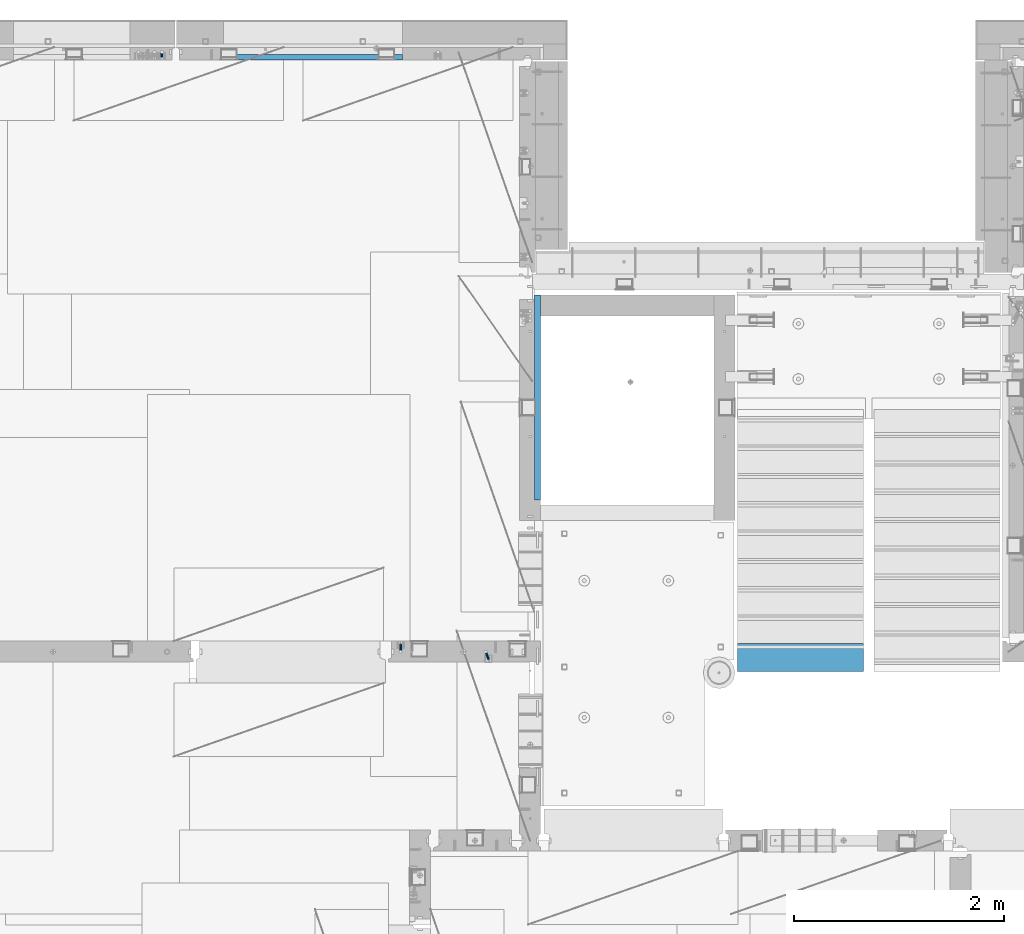
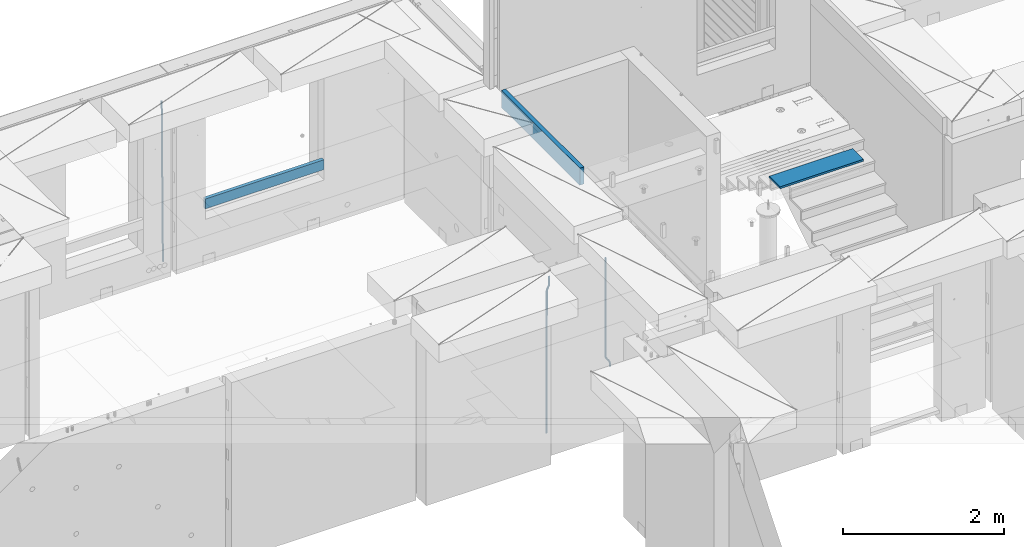
# One storey, part 113 of 341: 6 beams, 5 elements without a shape of their own.
"""IFC2X3 building model written with IfcOpenShell, lengths in millimetres."""

from ifc_helpers import new_model, si_unit, frame, origin_with_axes, place, context, subcontext, project, spatial, faceted_brep, material, type_object, element, aggregate, save


model = new_model("IFC2X3")

# Units and contexts
model_context = context("Model", 3, precision=1e-05, world=origin_with_axes())
body_context = subcontext(model_context, "Body", "Model", "MODEL_VIEW")
ifc_project = project(units=[si_unit("LENGTHUNIT", "METRE", prefix="MILLI"), si_unit("AREAUNIT", "SQUARE_METRE"), si_unit("VOLUMEUNIT", "CUBIC_METRE"), si_unit("MASSUNIT", "GRAM", prefix="KILO"), si_unit("TIMEUNIT", "SECOND"), si_unit("PLANEANGLEUNIT", "RADIAN"), si_unit("SOLIDANGLEUNIT", "STERADIAN"), si_unit("THERMODYNAMICTEMPERATUREUNIT", "DEGREE_CELSIUS"), si_unit("LUMINOUSINTENSITYUNIT", "LUMEN")], contexts=[model_context])

# Site, building, storey
site_placement = place(None, origin_with_axes())
site = spatial("IfcSite", under=ifc_project, at=site_placement, CompositionType="ELEMENT")
building_placement = place(site_placement, origin_with_axes())
building = spatial("IfcBuilding", under=site, at=building_placement, CompositionType="ELEMENT")
storey_placement = place(building_placement, origin_with_axes())
storey = spatial("IfcBuildingStorey", under=building, at=storey_placement, Name="5", CompositionType="ELEMENT", Elevation=0.0)

# Assembly, beams
assembly_1_placement = place(storey_placement, origin_with_axes())
assembly_1 = element("IfcElementAssembly", 1, at=assembly_1_placement, inside=storey, AssemblyPlace="NOTDEFINED", PredefinedType="REINFORCEMENT_UNIT")
ifc_material_1 = material()
beam_type_1 = type_object("IfcBeamType", Name="D20", PredefinedType="NOTDEFINED")
beam_1_placement = place(assembly_1_placement, frame((17285.016478657, 16980.0, 96407.5), z_axis=(-0.000415599999849952, -0.999999913638316, 0.0), x_axis=(-6.05680000062309e-05, -4.00000390151988e-09, -0.999999998165759)))
beam_1 = element("IfcBeam", 2, at=beam_1_placement, type_object=beam_type_1, material=ifc_material_1, Name="JM20", ObjectType="D20", context=body_context, shape_type="Brep", body=[
    faceted_brep([(0.000459931368823163, -9.99999998942076, 0.0), (0.000325058383168653, -7.07106780439426, -7.07106781187031), (1498.53016917036, -7.00214571310062, -7.07110244258729), (1498.53030404639, -9.93107788867201, -3.46394881489687e-05), (0.0, 0.0, -10.0), (1498.52984388257, 0.0689220912790915, -10.0000346307206), (-0.000325382832670584, 7.07106780437971, -7.07106781186667), (1498.52951872915, 7.13998989566971, -7.07110244258365), (-0.000459931412478909, 9.9999999894244, 0.0), (1498.52938418057, 10.0689220807144, -3.46307206200436e-05), (-0.000325058426824398, 7.07106780439062, 7.07106781186667), (1498.52951905355, 7.13998989568427, 7.07103318114605), (0.0, 0.0, 10.0), (1498.52984434133, 0.0689220913009194, 9.99996536927938), (0.000325382789014839, -7.07106780437607, 7.07106781186303), (1498.53016949476, -7.00214571308607, 7.07103318114241), (1512.41720874803, -5.73582294623338, -3.78448857876356), (1509.77427058959, -8.90577003658836, 2.66104918808924), (1506.12781116656, -6.30933666407145, 8.86914963737581), (1503.61387695429, 0.5325217154641, 11.203191722434), (1503.70509651935, 7.6119372551475, 8.29592524499458), (1506.34803467779, 10.7818843455061, 1.85038747814542), (1509.99449410092, 8.18545097300375, -4.35771297110477), (1512.50842831319, 1.34359259344637, -6.6917550561775), (1523.10793428493, 4.85819958866705, 2.43339327473223), (1522.94729923509, -2.24423288682374, 5.28089974098111), (1518.68801206884, 11.068066365151, 3.12656423834051), (1512.27666307625, 12.7477117054659, 6.95436248228361), (1507.62956859401, 8.91322214926913, 11.6745157093537), (1507.46893354415, 1.81078967378926, 14.5220221756208), (1511.88885576031, -4.39907710268017, 13.8288512120525), (1518.30020474852, -6.07872245333419, 10.0010529750907), (1556.47190306216, 16.2553988912259, 53.3150705600565), (1551.82480858495, 12.4209093455574, 58.0352237797015), (1556.63253811194, 23.3578313666767, 50.4675640938258), (1552.2126158958, 29.5676981431861, 51.1607350575687), (1545.80126690332, 31.2473434836029, 54.9885333017664), (1541.1541724212, 27.4128539274789, 59.7086865290003), (1540.99353737144, 20.3104214520208, 62.5561929952273), (1545.41345958759, 14.100554675515, 61.8630220314881), (1560.39637396604, 17.5567067062075, 56.6936612143036), (1557.75345399432, 14.386777545431, 63.1392152562548), (1554.10697584673, 16.9832211248868, 69.3473004384578), (1551.59299696748, 23.8250760096525, 71.6813046576062), (1551.6841720884, 30.9044764000282, 68.7739998967481), (1554.32709206025, 34.0744055607975, 62.3284458548405), (1557.97357020773, 31.4779619813417, 56.1203606726085), (1560.48754908697, 24.6361070965759, 53.7863564534418), (1565.57152260729, 25.0997628321384, 54.9895678972971), (1565.57195097132, 18.0287166318594, 57.9185522284643), (1565.57109441068, 32.1708522292429, 57.9184479422765), (1565.5709172132, 35.0998365550477, 64.9894941556158), (1565.57109481466, 32.1709565155361, 72.0605835657152), (1565.57152317863, 25.0999103152426, 74.9895678968714), (1565.5719513753, 18.0288209181526, 72.0606878518956), (1565.57212857006, 15.0998365824271, 64.9896416479532), (1617.49891294041, 18.0318617339399, 57.9185507229813), (1617.49909054188, 15.1029816944028, 64.9896401330443), (1617.49848457637, 25.1029079342443, 54.989566391796), (1617.49805637961, 32.1739973313524, 57.9184464367172), (1617.49787918197, 35.1029816571718, 64.9894926500019), (1617.49805678344, 32.1741016176347, 72.0605820600649), (1617.49848514747, 25.1030554173267, 74.9895663912539), (1617.49891334424, 18.0319660202294, 72.060686346329)], [[[0, 1, 2, 3]], [[1, 4, 5, 2]], [[4, 6, 7, 5]], [[6, 8, 9, 7]], [[8, 10, 11, 9]], [[10, 12, 13, 11]], [[12, 14, 15, 13]], [[14, 0, 3, 15]], [[14, 12, 10, 8, 6, 4, 1, 0]], [[3, 2, 16, 17]], [[15, 3, 17, 18]], [[13, 15, 18, 19]], [[11, 13, 19, 20]], [[9, 11, 20, 21]], [[7, 9, 21, 22]], [[5, 7, 22, 23]], [[2, 5, 23, 16]], [[23, 24, 25, 16]], [[22, 26, 24, 23]], [[21, 27, 26, 22]], [[20, 28, 27, 21]], [[19, 29, 28, 20]], [[18, 30, 29, 19]], [[17, 31, 30, 18]], [[16, 25, 31, 17]], [[31, 25, 32, 33]], [[25, 24, 34, 32]], [[24, 26, 35, 34]], [[26, 27, 36, 35]], [[27, 28, 37, 36]], [[28, 29, 38, 37]], [[29, 30, 39, 38]], [[30, 31, 33, 39]], [[33, 32, 40, 41]], [[39, 33, 41, 42]], [[38, 39, 42, 43]], [[37, 38, 43, 44]], [[36, 37, 44, 45]], [[35, 36, 45, 46]], [[34, 35, 46, 47]], [[32, 34, 47, 40]], [[47, 48, 49, 40]], [[46, 50, 48, 47]], [[45, 51, 50, 46]], [[44, 52, 51, 45]], [[43, 53, 52, 44]], [[42, 54, 53, 43]], [[41, 55, 54, 42]], [[40, 49, 55, 41]], [[55, 49, 56, 57]], [[49, 48, 58, 56]], [[48, 50, 59, 58]], [[50, 51, 60, 59]], [[51, 52, 61, 60]], [[52, 53, 62, 61]], [[53, 54, 63, 62]], [[54, 55, 57, 63]], [[58, 59, 60, 61, 62, 63, 57, 56]]]),
])
beam_2_placement = place(assembly_1_placement, frame((16475.016478657, 16980.0, 96407.5), z_axis=(-0.000415599999849952, -0.999999913638316, 0.0), x_axis=(-6.05680000062309e-05, -4.00000390151988e-09, -0.999999998165759)))
beam_2 = element("IfcBeam", 3, at=beam_2_placement, type_object=beam_type_1, material=ifc_material_1, Name="JM20", ObjectType="D20", context=body_context, shape_type="Brep", body=[
    faceted_brep([(-0.00060564729210455, -9.99999998165731, 0.0), (-0.000428079845733009, -7.07106779890455, -7.07106781186667), (109.663992146438, -7.07770969181365, -7.07106505070624), (109.663814574931, -10.0066418742208, 2.76014907285571e-06), (0.0, 0.0, -10.0), (109.664420484245, -0.00664189292001538, -9.99999723883957), (0.00042843479604926, 7.07106779888636, -7.07106781186303), (109.66484867355, 7.0644259059809, -7.07106505070988), (0.00060564729210455, 9.99999998166459, 3.63797880709171e-12), (109.665025886861, 9.99335808875549, 2.76115679298528e-06), (0.000428079845733009, 7.07106779890819, 7.07106781186667), (109.664848315049, 7.06442590600273, 7.07107057301982), (0.0, 0.0, 10.0), (109.664419977242, -0.00664189288727357, 10.0000027611604), (-0.000428434810601175, -7.07106779888272, 7.07106781186667), (109.663991787937, -7.07770969179182, 7.07107057302346), (123.019465653822, -0.00769783093346632, 8.49481275451399), (122.368218641306, 7.06342149385819, 5.63932810477127), (120.794596020874, 9.9924781119953, -1.25436342694593), (119.220404581531, 7.06367038153257, -8.14803083615698), (118.567784318744, -0.00734585062309634, -11.0034572490222), (119.219031331319, -7.07846517541839, -8.14797259927946), (120.79265395175, -10.0075217935628, -1.25428106757317), (122.366845391021, -7.07871406308914, 5.63938634164515), (134.432358609134, -7.0801380724879, 1.41616492140383), (135.704448506891, -0.00919495208290755, 4.05476198080942), (131.363125973905, -10.0087693538771, -4.95420191149606), (128.294665451453, -7.07953630984775, -11.3246640276848), (127.024439601548, -0.00834393120385357, -13.9634911148387), (128.296529499246, 7.06259918918295, -11.3248940553931), (131.365762135116, 9.99123047017565, -4.95452722118716), (134.434222657001, 7.06199742654644, 1.41593489364823), (232.333181448281, -7.09406463311461, -61.4435769522424), (235.401641971155, -10.0232976755033, -55.0731148385494), (231.062955598129, -0.0228722546671634, -64.0824040398293), (232.335045495653, 7.04807086590154, -61.4438069808093), (235.404278131435, 9.97670214732716, -55.0734401467271), (238.472738653494, 7.0474691041527, -48.7029780316807), (239.742964503646, -0.0237232742911146, -46.0641509440975), (238.470874606137, -7.09466639485981, -48.7027480031138), (248.152386176487, -0.0244396446978499, -49.0133708264948), (247.497266945589, 7.04670033489674, -51.8679184167595), (245.915123067214, 9.97580676374491, -58.7596380886316), (244.332752967632, 7.04704882145597, -65.6514539264135), (243.677087590491, -0.0239468102772662, -68.5062336817027), (244.33220682136, -7.09508678989368, -65.651686091438), (245.914350699837, -10.0241932187346, -58.7599664195659), (247.496720799376, -7.09543527645292, -51.8681505817658), (256.999396693936, -7.09531210125351, -52.9566469665442), (257.006072236094, -0.0243248818260327, -50.0275278254703), (256.982439129002, -10.0240497531304, -60.0277750206151), (256.965133057005, -7.09492303985826, -67.0987410777925), (256.957616135987, -0.0237746659149707, -70.0274691179584), (256.964291678203, 7.04721255350523, -67.0983499769027), (256.981249241362, 9.97595020465087, -60.027221921624), (256.998555315135, 7.04682349210998, -52.9562558656398), (2308.84129044529, -6.97271028710384, -72.0700484847293), (2308.85859651901, -9.9018369995174, -64.9990824287343), (2308.83377352433, 0.0984380867485015, -74.9987765249425), (2308.84044906651, 7.16942530619053, -72.0696573839123), (2308.85740662973, 10.0981629574344, -64.9985293286554), (2308.87471270347, 7.16903624502447, -57.9275632726531), (2308.88222962443, 0.0978878711684956, -54.9988352324472), (2308.87555408225, -6.9730993482699, -57.9279543734738), (2309.36197244871, -6.97267927451685, -72.0713099986351), (2309.37071429225, -9.90180649703325, -65.000323193126), (2309.3579998037, 0.0984693104364851, -75.0000466259553), (2309.3611234788, 7.16945631832277, -72.0709188794244), (2309.36951366749, 10.0981934592819, -64.9997700670392), (2309.37825551104, 7.16906623676914, -57.9287832615337), (2309.38222815606, 0.0979176518158056, -55.0000466342135), (2309.37910448095, -6.97306935607776, -57.929174380748), (2309.8826559803, -6.97264773775169, -72.0713100117428), (2309.88283356852, -9.90177547898566, -65.0003232060189), (2309.88222762165, 0.0985010618751403, -75.0000466391502), (2309.88179941924, 7.16948785463319, -72.0709188925321), (2309.88162220824, 10.0982244766819, -64.9997700799322), (2309.88179979647, 7.16909673544797, -57.9287832742084), (2309.88222815514, 0.0979479358211393, -55.0000466468009), (2309.88265635754, -6.97303885693691, -57.9291743934191), (2417.50042500655, -6.96612954309967, -72.0713127206036), (2417.50060259478, -9.89525728433364, -65.0003259148798), (2417.49999664789, 0.105019256523519, -75.0000493480147), (2417.49956844548, 7.17600604928157, -72.0709216013965), (2417.49939123449, 10.1047426713303, -64.9997727887931), (2417.49956882271, 7.17561493009634, -57.9287859830729), (2417.49999718138, 0.104466130473156, -55.0000493556618), (2417.50042538378, -6.96652066228489, -57.9291771022799)], [[[0, 1, 2, 3]], [[1, 4, 5, 2]], [[4, 6, 7, 5]], [[6, 8, 9, 7]], [[8, 10, 11, 9]], [[10, 12, 13, 11]], [[12, 14, 15, 13]], [[14, 0, 3, 15]], [[14, 12, 10, 8, 6, 4, 1, 0]], [[11, 13, 16, 17]], [[9, 11, 17, 18]], [[7, 9, 18, 19]], [[5, 7, 19, 20]], [[2, 5, 20, 21]], [[3, 2, 21, 22]], [[15, 3, 22, 23]], [[13, 15, 23, 16]], [[23, 24, 25, 16]], [[22, 26, 24, 23]], [[21, 27, 26, 22]], [[20, 28, 27, 21]], [[19, 29, 28, 20]], [[18, 30, 29, 19]], [[17, 31, 30, 18]], [[16, 25, 31, 17]], [[26, 27, 32, 33]], [[27, 28, 34, 32]], [[28, 29, 35, 34]], [[29, 30, 36, 35]], [[30, 31, 37, 36]], [[31, 25, 38, 37]], [[25, 24, 39, 38]], [[24, 26, 33, 39]], [[37, 38, 40, 41]], [[36, 37, 41, 42]], [[35, 36, 42, 43]], [[34, 35, 43, 44]], [[32, 34, 44, 45]], [[33, 32, 45, 46]], [[39, 33, 46, 47]], [[38, 39, 47, 40]], [[47, 48, 49, 40]], [[46, 50, 48, 47]], [[45, 51, 50, 46]], [[44, 52, 51, 45]], [[43, 53, 52, 44]], [[42, 54, 53, 43]], [[41, 55, 54, 42]], [[40, 49, 55, 41]], [[50, 51, 56, 57]], [[51, 52, 58, 56]], [[52, 53, 59, 58]], [[53, 54, 60, 59]], [[54, 55, 61, 60]], [[55, 49, 62, 61]], [[49, 48, 63, 62]], [[48, 50, 57, 63]], [[57, 56, 64, 65]], [[56, 58, 66, 64]], [[58, 59, 67, 66]], [[59, 60, 68, 67]], [[60, 61, 69, 68]], [[61, 62, 70, 69]], [[62, 63, 71, 70]], [[63, 57, 65, 71]], [[65, 64, 72, 73]], [[64, 66, 74, 72]], [[66, 67, 75, 74]], [[67, 68, 76, 75]], [[68, 69, 77, 76]], [[69, 70, 78, 77]], [[70, 71, 79, 78]], [[71, 65, 73, 79]], [[73, 72, 80, 81]], [[72, 74, 82, 80]], [[74, 75, 83, 82]], [[75, 76, 84, 83]], [[76, 77, 85, 84]], [[77, 78, 86, 85]], [[78, 79, 87, 86]], [[79, 73, 81, 87]], [[82, 83, 84, 85, 86, 87, 81, 80]]]),
])
aggregate(assembly_1, [beam_1, beam_2])

# Assembly, beam
assembly_2_placement = place(storey_placement, origin_with_axes())
assembly_2 = element("IfcElementAssembly", 4, at=assembly_2_placement, inside=storey, AssemblyPlace="NOTDEFINED", PredefinedType="REINFORCEMENT_UNIT")
ifc_material_2 = material(Name="CONCRETE/C25/30")
beam_type_2 = type_object("IfcBeamType", Name="260X60", PredefinedType="NOTDEFINED")
beam_3_placement = place(assembly_2_placement, frame((17779.9999105288, 18424.9992663657, 96600.0), z_axis=(0.0, 0.0, 1.0), x_axis=(0.0, 1.0, 0.0)))
beam_3 = element("IfcBeam", 5, at=beam_3_placement, type_object=beam_type_2, material=ifc_material_2, ObjectType="260X60", context=body_context, shape_type="Brep", body=[
    faceted_brep([(0.0, 30.0, -130.0), (0.0, 30.0, 130.0), (1954.9989445891, 30.0, 130.0), (1954.9989445891, 30.0, -130.0), (0.0, -30.0, 130.0), (1954.9989445891, -30.0, 130.0), (0.0, -30.0, -130.0), (1954.9989445891, -30.0, -130.0)], [[[0, 1, 2, 3]], [[1, 4, 5, 2]], [[4, 6, 7, 5]], [[6, 0, 3, 7]], [[5, 7, 3, 2]], [[6, 4, 1, 0]]]),
])
aggregate(assembly_2, [beam_3])

assembly_3_placement = place(storey_placement, origin_with_axes())
assembly_3 = element("IfcElementAssembly", 6, at=assembly_3_placement, inside=storey, AssemblyPlace="NOTDEFINED", PredefinedType="REINFORCEMENT_UNIT")
beam_type_3 = type_object("IfcBeamType", Name="D25", PredefinedType="NOTDEFINED")
beam_4_placement = place(assembly_3_placement, frame((14200.1300000039, 22654.999995444, 93989.68), z_axis=(-0.000205762999925498, 0.999642804629538, -0.0267249099901004), x_axis=(4.30000201928125e-08, 0.0267249099948059, 0.999642825806181)))
beam_4 = element("IfcBeam", 7, at=beam_4_placement, type_object=beam_type_3, material=ifc_material_1, Name="JM25", ObjectType="D25", context=body_context, shape_type="Brep", body=[
    faceted_brep([(-7.41420080885291e-08, -12.5, -3.63797880709171e-12), (-6.42030499875546e-08, -10.8253175473074, -6.25000000000364), (60.3237677085563, -10.8253175348218, -6.24999999383726), (60.3237677118304, -12.4999999875163, 6.16273609921336e-09), (-3.70782800018787e-08, -6.25000000000364, -10.8253175473074), (60.3237677054713, -6.24999998751628, -10.825317541141), (-1.45519152283669e-11, -3.63797880709171e-12, -12.5), (60.3237677033903, 1.24837242765352e-08, -12.4999999938373), (3.70637280866504e-08, 6.25, -10.8253175473074), (60.323767702881, 6.25000001248372, -10.825317541141), (6.42030499875546e-08, 10.8253175473001, -6.25000000000364), (60.3237677040888, 10.8253175597911, -6.24999999383726), (7.41420080885291e-08, 12.4999999999927, 0.0), (60.3237677066645, 12.5000000124837, 6.15909812040627e-09), (6.42176019027829e-08, 10.8253175473001, 6.24999999999636), (60.3237677099241, 10.8253175597893, 6.25000000616274), (3.70928319171071e-08, 6.24999999999636, 10.8253175473037), (60.3237677130091, 6.25000001248554, 10.8253175534701), (1.45519152283669e-11, -3.63797880709171e-12, 12.4999999999964), (60.3237677151046, 1.24837242765352e-08, 12.5000000061627), (-3.7049176171422e-08, -6.25000000000364, 10.8253175473001), (60.3237677156139, -6.24999998751628, 10.8253175534701), (-6.41884980723262e-08, -10.8253175473074, 6.25), (60.3237677144207, -10.82531753482, 6.25000000616274), (61.0758245489851, -10.8253175346654, -6.24999999375723), (60.991802792938, -12.4999999843931, 6.22458173893392e-09), (61.1373109934648, -6.24999998734893, -10.8253175410573), (61.1598041100515, 1.26583472592756e-08, -12.49999999375), (61.1372768863075, 6.25000001265289, -10.8253175410609), (61.0757654736371, 10.8253175599439, -6.24999999376087), (60.9917690322181, 12.5000000156033, 6.22458173893392e-09), (60.907747276171, 10.8253175599111, 6.25000000622094), (60.8462608316913, 6.25000001259286, 10.8253175535247), (60.8237677151046, 1.25892256619409e-08, 12.5000000062173), (60.8462949388486, -6.24999998740714, 10.825317553521), (60.9078063515044, -10.8253175347018, 6.25000000622458), (61.8276096861373, -10.8253134314764, -6.22978616751061), (61.6596309735614, -12.4999963425144, 0.017955953906494), (61.9505603643775, -6.24999554869282, -10.8034510785947), (61.9955384732893, 4.57403257314581e-06, -12.4775289599711), (61.950492164935, 6.25000445112164, -10.8034519952598), (61.827491561271, 10.8253216628109, -6.22978775521551), (61.6594945747056, 12.5000036571128, 0.0179541205834539), (61.4915158621152, 10.8253207460766, 6.26569624199692), (61.3685651839041, 6.25000286329123, 10.8393611530882), (61.3235870749922, 2.74056583293714e-06, 12.5134390344683), (61.3686333833321, -6.24999713652323, 10.8393620697534), (61.491633986996, -10.8253143482107, 6.26569782971274), (146.560019984419, -10.8248509682762, -3.95152056365259), (146.392041271829, -12.4995338793105, 2.29622155776815), (146.682970662645, -6.24953308548902, -8.52518547473665), (146.727948771557, 0.000467037238195189, -10.1992633561131), (146.682902463217, 6.25046691432544, -8.5251863914018), (146.559901859553, 10.8257841260165, -3.95152215136113), (146.391904872988, 12.5004661203184, 2.29621972444511), (146.223926160397, 10.8257832092804, 8.54396184585858), (146.100975482186, 6.25046532649503, 13.1176267569463), (146.05599737326, 0.000465203767817002, 14.7917046383263), (146.1010436816, -6.24953467331943, 13.1176276736078), (146.224044285264, -10.8248518850105, 8.54396343356711), (147.111078313566, -10.8248479606373, -3.93670383375138), (146.994353869159, -12.4995305919347, 2.31241640066946), (147.196513863179, -6.24953028260825, -8.5113774430065), (147.227768131459, 0.000469765214802464, -10.1858243278657), (147.19646656244, 6.25046971732081, -8.51137779775308), (147.110996386313, 10.8257871338483, -3.93670444818781), (146.994259267696, 12.5004694079234, 2.31241569117628), (146.877534823288, 10.8257867766279, 8.56153592559713), (146.792099273691, 6.25046909859884, 13.1362095348559), (146.760845005425, 0.000469050775791402, 14.8106564197114), (146.792146574429, -6.24953090133022, 13.1362098895952), (146.877616750571, -10.8248483178577, 8.56153654003356), (147.662305566744, -10.824846796575, -3.93093035933998), (147.596851102222, -12.4995293196007, 2.31872686942006), (147.710214487655, -6.24952919779389, -8.50599701707324), (147.727740708287, 0.000470821039925795, -10.1805876875078), (147.710188092009, 6.25047080218064, -8.50599715285716), (147.662259848148, 10.8257882979869, -3.93093059453167), (147.596798310929, 12.5004706803447, 2.31872659784494), (147.531343846407, 10.825788157319, 8.56838382660862), (147.483434925496, 6.25047055853611, 13.1434504843382), (147.465908704849, 0.000470539705929696, 14.8180411547801), (147.483461321142, -6.24952944143479, 13.1434506201294), (147.531389565032, -10.8248469372429, 8.56838406180032), (299.377341023079, -10.8245264100169, -2.34188905237897), (299.311886558571, -12.4992089330408, 3.90776817638471), (299.425249944004, -6.24920881123398, -6.9169557101086), (299.442776164637, 0.000791207598012988, -8.59154638054679), (299.425223548358, 6.25079118874055, -6.91695584589979), (299.377295304497, 10.8261086845469, -2.34188928757067), (299.311833767279, 12.5007910669028, 3.90776790480959), (299.246379302756, 10.8261085438789, 10.1574251335696), (299.198470381845, 6.25079094509601, 14.7324917913029), (299.180944161213, 0.000790926264016889, 16.4070824617411), (299.198496777492, -6.24920905487488, 14.7324919270868), (299.246425021367, -10.8245265506848, 10.157425368765), (299.95725460563, -10.824525185375, -2.33581512151068), (299.97179243555, -12.4991882411778, 3.91467976726199), (299.946633883446, -6.24920771019424, -6.91149481024331), (299.942748741494, 0.000792263424955308, -8.58630974019252), (299.946640200433, 6.25079228984941, -6.91149460340603), (299.957265546982, 10.8261099093088, -2.33581476325344), (299.971750386685, 12.5008117588586, 3.91467993563856), (299.98628821662, 10.8261101063945, 10.1651748323675), (299.996908938818, 6.25079263121188, 14.7408545211001), (300.000794080755, 0.000792657594502089, 16.415669451053), (299.996902621817, -6.24920736882996, 14.7408543142628), (299.986277275268, -10.8245249882893, 10.1651744741102), (300.537133734106, -10.8245269960826, -2.3445816610074), (300.631604424707, -12.4992095999223, 3.90470428084518), (300.467986846197, -6.24920933814974, -6.91937655855145), (300.442691613745, 0.000790702320955461, -8.59386781345165), (300.468025873881, 6.25079066179023, -6.91937684622826), (300.537201332045, 10.8261080984212, -2.34458215927589), (300.631682480074, 12.5007903999558, 3.90470370549519), (300.726153170675, 10.8261077961179, 10.1539896473478), (300.795300058599, 6.25079013818504, 14.7287845448955), (300.82059529105, 0.000790097714343574, 16.403275799792), (300.795261030915, -6.24920986175493, 14.7287848325686), (300.726085572751, -10.8245272983859, 10.1539901456163), (2293.32930409742, -10.8307295605009, -32.4713622331001), (2293.42377478865, -12.5054121599169, -26.2220762900724), (2293.26015720774, -6.2554119058077, -37.0461571338565), (2293.23486197284, -0.00541186651753378, -38.7206483931477), (2293.26019623051, 6.24458809413409, -37.0461574303008), (2293.32937168686, 10.8199055340046, -32.4713627465644), (2293.42385283421, 12.4945878399631, -26.2220768829684), (2293.51832352545, 10.8199052405434, -19.972790939948), (2293.58747041514, 6.24458758585388, -15.3979960391844), (2293.61276565003, -0.00541245343265473, -13.7235047798931), (2293.58743139236, -6.25541241408428, -15.3979957427327), (2293.51825593603, -10.8307298539585, -19.9727904264691), (2294.0420846676, -10.8307317859326, -32.4821379598216), (2294.03681932652, -12.5054140739521, -26.2313442200393), (2294.06778164886, -6.2554144273563, -37.0583666982457), (2294.10702478497, -0.00541458957013674, -38.7338336404937), (2294.14929890928, 6.24458531819619, -37.0595987724118), (2294.18327670435, 10.8199028679592, -32.4842719748667), (2294.1998538474, 12.4945854171456, -26.2338083683717), (2294.19458850632, 10.819903129126, -19.9830146285858), (2294.16889152506, 6.24458577054975, -15.4067858901581), (2294.12964838895, -0.0054140672327776, -13.7313189479173), (2294.08737426462, -6.2554139749991, -15.4055538159919), (2294.05339646956, -10.8307315247621, -19.9808806135297), (2294.75482297382, -10.84002603931, -32.4726521173216), (2294.64982751427, -12.513407826169, -26.2231856868602), (2294.87535820232, -6.26594539088183, -37.0476186524102), (2294.97913588268, -0.0167870967634371, -38.7222267036377), (2295.0383488692, 6.23299192477134, -37.0477663960555), (2295.03713108998, 10.8087684320271, -32.4729080168181), (2294.97580884799, 12.4844668051373, -26.2234811741473), (2294.87081338844, 10.8110850182784, -19.9740147436787), (2294.7502781599, 6.23700436985018, -15.3990482086047), (2294.64650047956, -0.0121539242718427, -13.7244401573698), (2294.58728749304, -6.26193294580662, -15.3989004649666), (2294.58850527227, -10.8377094530588, -19.9737588441894), (2316.44667268227, -11.1228921988077, -32.1839550346631), (2316.34167722271, -12.7962739856739, -25.9344886042054), (2316.56720791078, -6.54881155039038, -36.7589215697517), (2316.67098559113, -0.299653256264719, -38.4335296209792), (2316.73019857766, 5.95012576527006, -36.759069313397), (2316.72898079845, 10.5259022725259, -32.1842109341669), (2316.66765855643, 12.2016006456361, -25.9347840914961), (2316.56266309689, 10.5282188587698, -19.6853176610275), (2316.44212786836, 5.95413821035254, -15.1103511259389), (2316.33835018802, -0.295020083769487, -13.4357430747186), (2316.27913720149, -6.54479910530426, -15.1102033823008), (2316.28035498071, -11.1205756125637, -19.685061761531), (2317.13234804722, -11.1318335458927, -32.1748293731798), (2317.04181141085, -12.8054038787741, -25.9251705100723), (2317.2154741603, -6.5572650749491, -36.7502937866229), (2317.26891617525, -0.307450393454928, -38.4255717558117), (2317.27835434731, 5.94297770185585, -36.7517739018112), (2317.24125972588, 10.5192220504723, -32.1773930078925), (2317.16757178486, 12.1950816748285, -25.9281307404563), (2317.0770351485, 10.5215113419545, -19.6784718773561), (2316.99390903539, 5.94694287101083, -15.1030074639057), (2316.94046702047, -0.302871810494253, -13.4277294947169), (2316.9310288484, -6.55329990579412, -15.1015273487101), (2316.96812346982, -11.1295442544142, -19.6759082426288), (2317.81808136747, -11.1298054502913, -32.1659056455355), (2317.74200467508, -12.803315894289, -25.9160547315114), (2317.86379538118, -6.55536082026447, -36.7418676070083), (2317.8668976831, -0.305700748642266, -38.417815303761), (2317.82655701396, 5.94458339541234, -36.7446799039099), (2317.75358262347, 10.5207330230332, -32.1707766866384), (2317.66752794063, 12.1965725370646, -25.9216793252963), (2317.59145124823, 10.5230620930706, -19.6718284112721), (2317.54573723453, 5.94861746304377, -15.0958664497994), (2317.54263493262, -0.301042608574789, -13.4199187530394), (2317.58297560175, -6.55132675263303, -15.0930541529051), (2317.65594999224, -11.1274763802539, -19.6669573701693), (2417.81884292323, -10.831603083323, -30.8687911350135), (2417.74276623082, -12.505113527317, -24.618940220982), (2417.86455693691, -6.25715845329614, -35.4447530964935), (2417.86765923884, -0.00749838167394046, -37.1207007932499), (2417.82731856969, 6.24278576237703, -35.4475653933878), (2417.75434417921, 10.8189353900088, -30.8736621761236), (2417.66828949639, 12.494774904033, -24.6245648147851), (2417.59221280397, 10.8212644600353, -18.3747139007501), (2417.54649879028, 6.2468198300121, -13.79875193927), (2417.54339648837, -0.00284024161010166, -12.1228042425173), (2417.5837371575, -6.25312438566107, -13.795939642383), (2417.65671154798, -10.8292740132893, -18.3698428596399)], [[[0, 1, 2, 3]], [[1, 4, 5, 2]], [[4, 6, 7, 5]], [[6, 8, 9, 7]], [[8, 10, 11, 9]], [[10, 12, 13, 11]], [[12, 14, 15, 13]], [[14, 16, 17, 15]], [[16, 18, 19, 17]], [[18, 20, 21, 19]], [[20, 22, 23, 21]], [[22, 0, 3, 23]], [[22, 20, 18, 16, 14, 12, 10, 8, 6, 4, 1, 0]], [[3, 2, 24, 25]], [[2, 5, 26, 24]], [[5, 7, 27, 26]], [[7, 9, 28, 27]], [[9, 11, 29, 28]], [[11, 13, 30, 29]], [[13, 15, 31, 30]], [[15, 17, 32, 31]], [[17, 19, 33, 32]], [[19, 21, 34, 33]], [[21, 23, 35, 34]], [[23, 3, 25, 35]], [[25, 24, 36, 37]], [[24, 26, 38, 36]], [[26, 27, 39, 38]], [[27, 28, 40, 39]], [[28, 29, 41, 40]], [[29, 30, 42, 41]], [[30, 31, 43, 42]], [[31, 32, 44, 43]], [[32, 33, 45, 44]], [[33, 34, 46, 45]], [[34, 35, 47, 46]], [[35, 25, 37, 47]], [[37, 36, 48, 49]], [[36, 38, 50, 48]], [[38, 39, 51, 50]], [[39, 40, 52, 51]], [[40, 41, 53, 52]], [[41, 42, 54, 53]], [[42, 43, 55, 54]], [[43, 44, 56, 55]], [[44, 45, 57, 56]], [[45, 46, 58, 57]], [[46, 47, 59, 58]], [[47, 37, 49, 59]], [[49, 48, 60, 61]], [[48, 50, 62, 60]], [[50, 51, 63, 62]], [[51, 52, 64, 63]], [[52, 53, 65, 64]], [[53, 54, 66, 65]], [[54, 55, 67, 66]], [[55, 56, 68, 67]], [[56, 57, 69, 68]], [[57, 58, 70, 69]], [[58, 59, 71, 70]], [[59, 49, 61, 71]], [[61, 60, 72, 73]], [[60, 62, 74, 72]], [[62, 63, 75, 74]], [[63, 64, 76, 75]], [[64, 65, 77, 76]], [[65, 66, 78, 77]], [[66, 67, 79, 78]], [[67, 68, 80, 79]], [[68, 69, 81, 80]], [[69, 70, 82, 81]], [[70, 71, 83, 82]], [[71, 61, 73, 83]], [[73, 72, 84, 85]], [[72, 74, 86, 84]], [[74, 75, 87, 86]], [[75, 76, 88, 87]], [[76, 77, 89, 88]], [[77, 78, 90, 89]], [[78, 79, 91, 90]], [[79, 80, 92, 91]], [[80, 81, 93, 92]], [[81, 82, 94, 93]], [[82, 83, 95, 94]], [[83, 73, 85, 95]], [[85, 84, 96, 97]], [[84, 86, 98, 96]], [[86, 87, 99, 98]], [[87, 88, 100, 99]], [[88, 89, 101, 100]], [[89, 90, 102, 101]], [[90, 91, 103, 102]], [[91, 92, 104, 103]], [[92, 93, 105, 104]], [[93, 94, 106, 105]], [[94, 95, 107, 106]], [[95, 85, 97, 107]], [[97, 96, 108, 109]], [[96, 98, 110, 108]], [[98, 99, 111, 110]], [[99, 100, 112, 111]], [[100, 101, 113, 112]], [[101, 102, 114, 113]], [[102, 103, 115, 114]], [[103, 104, 116, 115]], [[104, 105, 117, 116]], [[105, 106, 118, 117]], [[106, 107, 119, 118]], [[107, 97, 109, 119]], [[109, 108, 120, 121]], [[108, 110, 122, 120]], [[110, 111, 123, 122]], [[111, 112, 124, 123]], [[112, 113, 125, 124]], [[113, 114, 126, 125]], [[114, 115, 127, 126]], [[115, 116, 128, 127]], [[116, 117, 129, 128]], [[117, 118, 130, 129]], [[118, 119, 131, 130]], [[119, 109, 121, 131]], [[121, 120, 132, 133]], [[120, 122, 134, 132]], [[122, 123, 135, 134]], [[123, 124, 136, 135]], [[124, 125, 137, 136]], [[125, 126, 138, 137]], [[126, 127, 139, 138]], [[127, 128, 140, 139]], [[128, 129, 141, 140]], [[129, 130, 142, 141]], [[130, 131, 143, 142]], [[131, 121, 133, 143]], [[133, 132, 144, 145]], [[132, 134, 146, 144]], [[134, 135, 147, 146]], [[135, 136, 148, 147]], [[136, 137, 149, 148]], [[137, 138, 150, 149]], [[138, 139, 151, 150]], [[139, 140, 152, 151]], [[140, 141, 153, 152]], [[141, 142, 154, 153]], [[142, 143, 155, 154]], [[143, 133, 145, 155]], [[145, 144, 156, 157]], [[144, 146, 158, 156]], [[146, 147, 159, 158]], [[147, 148, 160, 159]], [[148, 149, 161, 160]], [[149, 150, 162, 161]], [[150, 151, 163, 162]], [[151, 152, 164, 163]], [[152, 153, 165, 164]], [[153, 154, 166, 165]], [[154, 155, 167, 166]], [[155, 145, 157, 167]], [[157, 156, 168, 169]], [[156, 158, 170, 168]], [[158, 159, 171, 170]], [[159, 160, 172, 171]], [[160, 161, 173, 172]], [[161, 162, 174, 173]], [[162, 163, 175, 174]], [[163, 164, 176, 175]], [[164, 165, 177, 176]], [[165, 166, 178, 177]], [[166, 167, 179, 178]], [[167, 157, 169, 179]], [[169, 168, 180, 181]], [[168, 170, 182, 180]], [[170, 171, 183, 182]], [[171, 172, 184, 183]], [[172, 173, 185, 184]], [[173, 174, 186, 185]], [[174, 175, 187, 186]], [[175, 176, 188, 187]], [[176, 177, 189, 188]], [[177, 178, 190, 189]], [[178, 179, 191, 190]], [[179, 169, 181, 191]], [[181, 180, 192, 193]], [[180, 182, 194, 192]], [[182, 183, 195, 194]], [[183, 184, 196, 195]], [[184, 185, 197, 196]], [[185, 186, 198, 197]], [[186, 187, 199, 198]], [[187, 188, 200, 199]], [[188, 189, 201, 200]], [[189, 190, 202, 201]], [[190, 191, 203, 202]], [[191, 181, 193, 203]], [[194, 195, 196, 197, 198, 199, 200, 201, 202, 203, 193, 192]]]),
])
aggregate(assembly_3, [beam_4])

assembly_4_placement = place(storey_placement, origin_with_axes())
assembly_4 = element("IfcElementAssembly", 8, at=assembly_4_placement, inside=storey, AssemblyPlace="NOTDEFINED", PredefinedType="REINFORCEMENT_UNIT")
ifc_material_3 = material(Name="TIMBER/T24")
beam_type_4 = type_object("IfcBeamType", PredefinedType="NOTDEFINED")
beam_5_placement = place(assembly_4_placement, frame((14784.9997107317, 22644.7399977209, 94680.0), z_axis=(0.0, 0.0, 1.0), x_axis=(1.0, 0.0, 0.0)))
beam_5 = element("IfcBeam", 9, at=beam_5_placement, type_object=beam_type_4, material=ifc_material_3, context=body_context, shape_type="Brep", body=[
    faceted_brep([(-3.63797880709171e-12, 24.9999999999964, -75.0), (-3.63797880709171e-12, 24.9999999999964, 75.0), (1710.00028926826, 25.0, 75.0), (1710.00028926826, 25.0, -75.0), (0.0, -25.0000000000073, 75.0), (1710.00028926826, -25.0, 75.0), (0.0, -25.0000000000073, -75.0), (1710.00028926826, -25.0, -75.0)], [[[0, 1, 2, 3]], [[1, 4, 5, 2]], [[4, 6, 7, 5]], [[6, 0, 3, 7]], [[5, 7, 3, 2]], [[6, 4, 1, 0]]]),
])
aggregate(assembly_4, [beam_5])

assembly_5_placement = place(storey_placement, origin_with_axes())
assembly_5 = element("IfcElementAssembly", 10, at=assembly_5_placement, inside=storey, Name="E9", AssemblyPlace="NOTDEFINED", PredefinedType="NOTDEFINED")
ifc_material_4 = material(Name="Undefined/C32/40")
beam_type_5 = type_object("IfcBeamType", PredefinedType="NOTDEFINED")
beam_6_placement = place(assembly_5_placement, frame((20885.0002457424, 16924.9998138874, 96745.3), z_axis=(0.0, 1.0, 0.0), x_axis=(-1.0, 3.00000001838171e-08, 0.0)))
beam_6 = element("IfcBeam", 11, at=beam_6_placement, type_object=beam_type_5, material=ifc_material_4, Name="E9", context=body_context, shape_type="Brep", body=[
    faceted_brep([(0.0, 15.0, -135.0), (0.0, 15.0, 135.0), (1200.0, 15.0, 135.0), (1200.0, 15.0, -135.0), (0.0, -15.0, 135.0), (1200.0, -15.0, 135.0), (0.0, -15.0, -135.0), (1200.0, -15.0, -135.0)], [[[0, 1, 2, 3]], [[1, 4, 5, 2]], [[4, 6, 7, 5]], [[6, 0, 3, 7]], [[5, 7, 3, 2]], [[6, 4, 1, 0]]]),
])
aggregate(assembly_5, [beam_6])

save(model, "model.ifc")
